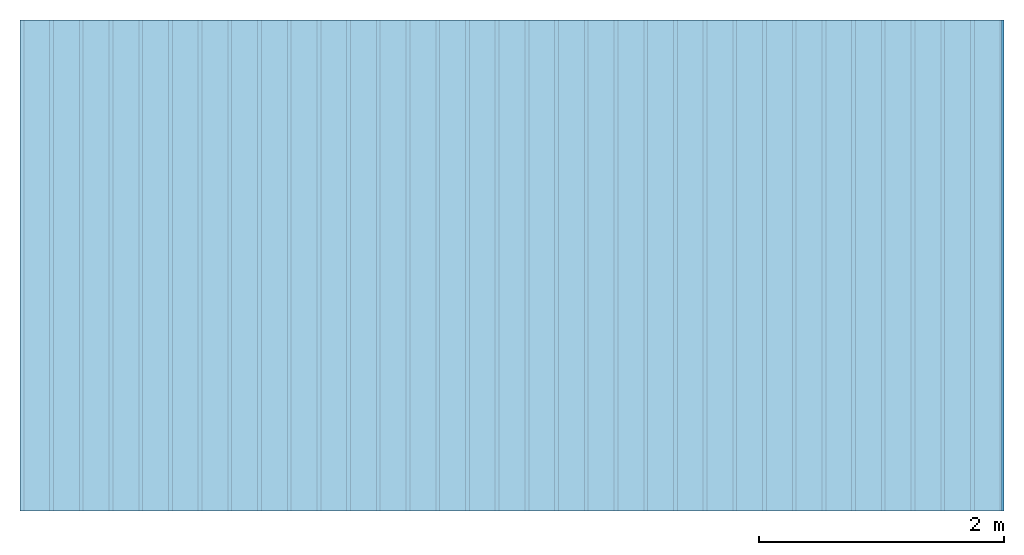
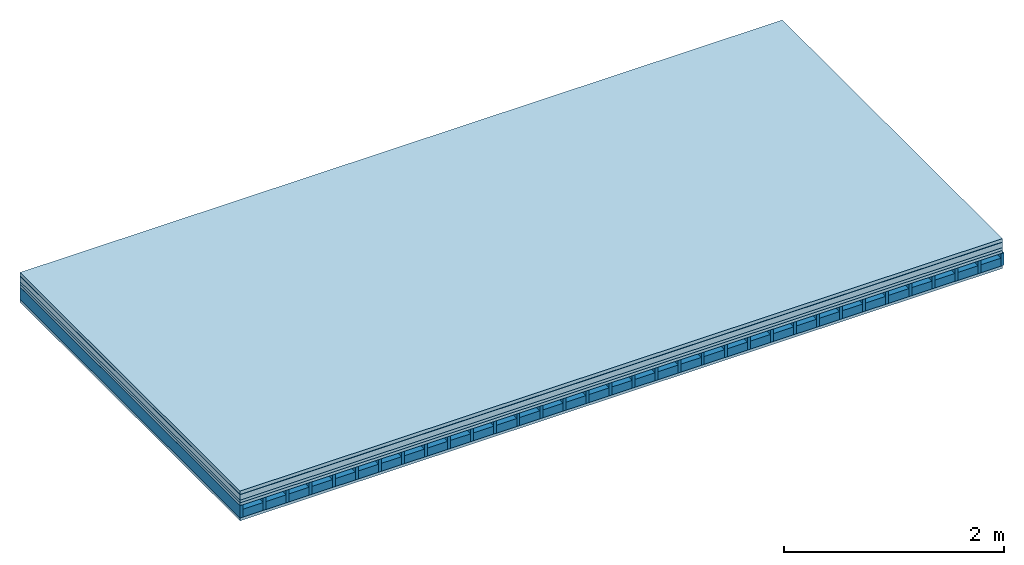
# One storey: 6 plates, 2 members, 1 element without a shape of its own.
"""IFC4 building model written with IfcOpenShell, lengths in metres."""

from ifc_helpers import new_model, si_unit, derived_unit, direction, frame, frame_2d, origin, origin_with_axes, place, context, project, spatial, rectangle, extrude, material, layer, layer_set, type_object, element, aggregate, save


model = new_model("IFC4")

# Units and contexts
plan_context = context("Plan", 3, precision=1e-05, world=origin(), true_north=direction((0.0, 1.0)))
model_context = context("Model", 3, precision=1e-05, world=origin(), true_north=direction((0.0, 1.0)))
ifc_project = project(units=[si_unit("LENGTHUNIT", "METRE"), derived_unit("SOUNDPRESSUREUNIT", [(si_unit("PRESSUREUNIT", "PASCAL", prefix="MICRO"), 0)]), si_unit("ENERGYUNIT", "JOULE", prefix="MEGA"), si_unit("MASSUNIT", "GRAM", prefix="KILO"), derived_unit("THERMALTRANSMITTANCEUNIT", [(si_unit("POWERUNIT", "WATT"), 1), (si_unit("AREAUNIT", "SQUARE_METRE"), -1), (si_unit("THERMODYNAMICTEMPERATUREUNIT", "KELVIN"), -1)]), derived_unit("AREADENSITYUNIT", [(si_unit("MASSUNIT", "GRAM", prefix="KILO"), 1), (si_unit("AREAUNIT", "SQUARE_METRE"), -1)]), derived_unit("USERDEFINED", [(si_unit("ENERGYUNIT", "JOULE", prefix="MEGA"), 1), (si_unit("AREAUNIT", "SQUARE_METRE"), -1)])], contexts=[plan_context, model_context])

# Site, building, storey
site = spatial("IfcSite", under=ifc_project)
building_placement = place(None, origin())
building = spatial("IfcBuilding", under=site, at=building_placement)
storey_placement = place(building_placement, origin())
storey = spatial("IfcBuildingStorey", under=building, at=storey_placement)

# Slab, members, plates
ifc_material_1 = material(Category="03.007")
ifc_layer_1 = layer(ifc_material_1, 0.038, Name="Flooring")
ifc_material_2 = material(Name="TS silent", Category="08.003")
ifc_layer_2 = layer(ifc_material_2, 0.0028, Name="layer")
ifc_material_3 = material(Name="Garden plates", Category="02.007")
ifc_layer_3 = layer(ifc_material_3, 0.06, Name="On-material")
ifc_material_4 = material(Name="EP2, 30mm")
ifc_layer_4 = layer(ifc_material_4, 0.03, Name="Impact sound insulation")
ifc_material_5 = material(Name="surface element sheathing above")
ifc_layer_5 = layer(ifc_material_5, 0.031, Name="Sub-floor")
ifc_layer_6 = layer(None, 0.138, Name="Supporting structure")
ifc_material_6 = material(Name="surface element sheathing below")
ifc_layer_7 = layer(ifc_material_6, 0.031, Name="Lower layer 1")
ifc_layer_set = layer_set([ifc_layer_1, ifc_layer_2, ifc_layer_3, ifc_layer_4, ifc_layer_5, ifc_layer_6, ifc_layer_7])
slab_type = type_object("IfcSlabType", Name="A2702", PredefinedType="NOTDEFINED", material=ifc_layer_set)
slab_placement = place(None, frame((0.0, 0.0, 0.0), z_axis=(0.0, 0.0, -1.0), x_axis=(1.0, 0.0, 0.0)))
slab = element("IfcSlab", 1, at=slab_placement, inside=storey, type_object=slab_type, material=ifc_layer_set, Name="Slab #1")
ifc_material_7 = material(Name="surface element LFE 12")
member_1_placement = place(slab_placement, origin())
member_1 = element("IfcMember", 2, at=member_1_placement, material=ifc_material_7, Name="Supporting structure", context=plan_context, shape_type="SweptSolid", body=[
    extrude(rectangle(XDim=0.031, YDim=0.138, at=frame_2d((0.0155, 0.069), x_axis=(1.0, 0.0))), frame((0.0, 4.0, 0.1618), z_axis=(0.0, -1.0, 0.0), x_axis=(1.0, 0.0, 0.0)), (0.0, 0.0, 1.0), 4.0),
    extrude(rectangle(XDim=0.031, YDim=0.138, at=frame_2d((0.0155, 0.069), x_axis=(1.0, 0.0))), frame((0.242, 4.0, 0.1618), z_axis=(0.0, -1.0, 0.0), x_axis=(1.0, 0.0, 0.0)), (0.0, 0.0, 1.0), 4.0),
    extrude(rectangle(XDim=0.031, YDim=0.138, at=frame_2d((0.0155, 0.069), x_axis=(1.0, 0.0))), frame((0.484, 4.0, 0.1618), z_axis=(0.0, -1.0, 0.0), x_axis=(1.0, 0.0, 0.0)), (0.0, 0.0, 1.0), 4.0),
    extrude(rectangle(XDim=0.031, YDim=0.138, at=frame_2d((0.0155, 0.069), x_axis=(1.0, 0.0))), frame((0.726, 4.0, 0.1618), z_axis=(0.0, -1.0, 0.0), x_axis=(1.0, 0.0, 0.0)), (0.0, 0.0, 1.0), 4.0),
    extrude(rectangle(XDim=0.031, YDim=0.138, at=frame_2d((0.0155, 0.069), x_axis=(1.0, 0.0))), frame((0.968, 4.0, 0.1618), z_axis=(0.0, -1.0, 0.0), x_axis=(1.0, 0.0, 0.0)), (0.0, 0.0, 1.0), 4.0),
    extrude(rectangle(XDim=0.031, YDim=0.138, at=frame_2d((0.0155, 0.069), x_axis=(1.0, 0.0))), frame((1.21, 4.0, 0.1618), z_axis=(0.0, -1.0, 0.0), x_axis=(1.0, 0.0, 0.0)), (0.0, 0.0, 1.0), 4.0),
    extrude(rectangle(XDim=0.031, YDim=0.138, at=frame_2d((0.0155, 0.069), x_axis=(1.0, 0.0))), frame((1.452, 4.0, 0.1618), z_axis=(0.0, -1.0, 0.0), x_axis=(1.0, 0.0, 0.0)), (0.0, 0.0, 1.0), 4.0),
    extrude(rectangle(XDim=0.031, YDim=0.138, at=frame_2d((0.0155, 0.069), x_axis=(1.0, 0.0))), frame((1.694, 4.0, 0.1618), z_axis=(0.0, -1.0, 0.0), x_axis=(1.0, 0.0, 0.0)), (0.0, 0.0, 1.0), 4.0),
    extrude(rectangle(XDim=0.031, YDim=0.138, at=frame_2d((0.0155, 0.069), x_axis=(1.0, 0.0))), frame((1.936, 4.0, 0.1618), z_axis=(0.0, -1.0, 0.0), x_axis=(1.0, 0.0, 0.0)), (0.0, 0.0, 1.0), 4.0),
    extrude(rectangle(XDim=0.031, YDim=0.138, at=frame_2d((0.0155, 0.069), x_axis=(1.0, 0.0))), frame((2.178, 4.0, 0.1618), z_axis=(0.0, -1.0, 0.0), x_axis=(1.0, 0.0, 0.0)), (0.0, 0.0, 1.0), 4.0),
    extrude(rectangle(XDim=0.031, YDim=0.138, at=frame_2d((0.0155, 0.069), x_axis=(1.0, 0.0))), frame((2.42, 4.0, 0.1618), z_axis=(0.0, -1.0, 0.0), x_axis=(1.0, 0.0, 0.0)), (0.0, 0.0, 1.0), 4.0),
    extrude(rectangle(XDim=0.031, YDim=0.138, at=frame_2d((0.0155, 0.069), x_axis=(1.0, 0.0))), frame((2.662, 4.0, 0.1618), z_axis=(0.0, -1.0, 0.0), x_axis=(1.0, 0.0, 0.0)), (0.0, 0.0, 1.0), 4.0),
    extrude(rectangle(XDim=0.031, YDim=0.138, at=frame_2d((0.0155, 0.069), x_axis=(1.0, 0.0))), frame((2.904, 4.0, 0.1618), z_axis=(0.0, -1.0, 0.0), x_axis=(1.0, 0.0, 0.0)), (0.0, 0.0, 1.0), 4.0),
    extrude(rectangle(XDim=0.031, YDim=0.138, at=frame_2d((0.0155, 0.069), x_axis=(1.0, 0.0))), frame((3.146, 4.0, 0.1618), z_axis=(0.0, -1.0, 0.0), x_axis=(1.0, 0.0, 0.0)), (0.0, 0.0, 1.0), 4.0),
    extrude(rectangle(XDim=0.031, YDim=0.138, at=frame_2d((0.0155, 0.069), x_axis=(1.0, 0.0))), frame((3.388, 4.0, 0.1618), z_axis=(0.0, -1.0, 0.0), x_axis=(1.0, 0.0, 0.0)), (0.0, 0.0, 1.0), 4.0),
    extrude(rectangle(XDim=0.031, YDim=0.138, at=frame_2d((0.0155, 0.069), x_axis=(1.0, 0.0))), frame((3.63, 4.0, 0.1618), z_axis=(0.0, -1.0, 0.0), x_axis=(1.0, 0.0, 0.0)), (0.0, 0.0, 1.0), 4.0),
    extrude(rectangle(XDim=0.031, YDim=0.138, at=frame_2d((0.0155, 0.069), x_axis=(1.0, 0.0))), frame((3.872, 4.0, 0.1618), z_axis=(0.0, -1.0, 0.0), x_axis=(1.0, 0.0, 0.0)), (0.0, 0.0, 1.0), 4.0),
    extrude(rectangle(XDim=0.031, YDim=0.138, at=frame_2d((0.0155, 0.069), x_axis=(1.0, 0.0))), frame((4.114, 4.0, 0.1618), z_axis=(0.0, -1.0, 0.0), x_axis=(1.0, 0.0, 0.0)), (0.0, 0.0, 1.0), 4.0),
    extrude(rectangle(XDim=0.031, YDim=0.138, at=frame_2d((0.0155, 0.069), x_axis=(1.0, 0.0))), frame((4.356, 4.0, 0.1618), z_axis=(0.0, -1.0, 0.0), x_axis=(1.0, 0.0, 0.0)), (0.0, 0.0, 1.0), 4.0),
    extrude(rectangle(XDim=0.031, YDim=0.138, at=frame_2d((0.0155, 0.069), x_axis=(1.0, 0.0))), frame((4.598, 4.0, 0.1618), z_axis=(0.0, -1.0, 0.0), x_axis=(1.0, 0.0, 0.0)), (0.0, 0.0, 1.0), 4.0),
    extrude(rectangle(XDim=0.031, YDim=0.138, at=frame_2d((0.0155, 0.069), x_axis=(1.0, 0.0))), frame((4.84, 4.0, 0.1618), z_axis=(0.0, -1.0, 0.0), x_axis=(1.0, 0.0, 0.0)), (0.0, 0.0, 1.0), 4.0),
    extrude(rectangle(XDim=0.031, YDim=0.138, at=frame_2d((0.0155, 0.069), x_axis=(1.0, 0.0))), frame((5.082, 4.0, 0.1618), z_axis=(0.0, -1.0, 0.0), x_axis=(1.0, 0.0, 0.0)), (0.0, 0.0, 1.0), 4.0),
    extrude(rectangle(XDim=0.031, YDim=0.138, at=frame_2d((0.0155, 0.069), x_axis=(1.0, 0.0))), frame((5.324, 4.0, 0.1618), z_axis=(0.0, -1.0, 0.0), x_axis=(1.0, 0.0, 0.0)), (0.0, 0.0, 1.0), 4.0),
    extrude(rectangle(XDim=0.031, YDim=0.138, at=frame_2d((0.0155, 0.069), x_axis=(1.0, 0.0))), frame((5.566, 4.0, 0.1618), z_axis=(0.0, -1.0, 0.0), x_axis=(1.0, 0.0, 0.0)), (0.0, 0.0, 1.0), 4.0),
    extrude(rectangle(XDim=0.031, YDim=0.138, at=frame_2d((0.0155, 0.069), x_axis=(1.0, 0.0))), frame((5.808, 4.0, 0.1618), z_axis=(0.0, -1.0, 0.0), x_axis=(1.0, 0.0, 0.0)), (0.0, 0.0, 1.0), 4.0),
    extrude(rectangle(XDim=0.031, YDim=0.138, at=frame_2d((0.0155, 0.069), x_axis=(1.0, 0.0))), frame((6.05, 4.0, 0.1618), z_axis=(0.0, -1.0, 0.0), x_axis=(1.0, 0.0, 0.0)), (0.0, 0.0, 1.0), 4.0),
    extrude(rectangle(XDim=0.031, YDim=0.138, at=frame_2d((0.0155, 0.069), x_axis=(1.0, 0.0))), frame((6.292, 4.0, 0.1618), z_axis=(0.0, -1.0, 0.0), x_axis=(1.0, 0.0, 0.0)), (0.0, 0.0, 1.0), 4.0),
    extrude(rectangle(XDim=0.031, YDim=0.138, at=frame_2d((0.0155, 0.069), x_axis=(1.0, 0.0))), frame((6.534, 4.0, 0.1618), z_axis=(0.0, -1.0, 0.0), x_axis=(1.0, 0.0, 0.0)), (0.0, 0.0, 1.0), 4.0),
    extrude(rectangle(XDim=0.031, YDim=0.138, at=frame_2d((0.0155, 0.069), x_axis=(1.0, 0.0))), frame((6.776, 4.0, 0.1618), z_axis=(0.0, -1.0, 0.0), x_axis=(1.0, 0.0, 0.0)), (0.0, 0.0, 1.0), 4.0),
    extrude(rectangle(XDim=0.031, YDim=0.138, at=frame_2d((0.0155, 0.069), x_axis=(1.0, 0.0))), frame((7.018, 4.0, 0.1618), z_axis=(0.0, -1.0, 0.0), x_axis=(1.0, 0.0, 0.0)), (0.0, 0.0, 1.0), 4.0),
    extrude(rectangle(XDim=0.031, YDim=0.138, at=frame_2d((0.0155, 0.069), x_axis=(1.0, 0.0))), frame((7.26, 4.0, 0.1618), z_axis=(0.0, -1.0, 0.0), x_axis=(1.0, 0.0, 0.0)), (0.0, 0.0, 1.0), 4.0),
    extrude(rectangle(XDim=0.031, YDim=0.138, at=frame_2d((0.0155, 0.069), x_axis=(1.0, 0.0))), frame((7.502, 4.0, 0.1618), z_axis=(0.0, -1.0, 0.0), x_axis=(1.0, 0.0, 0.0)), (0.0, 0.0, 1.0), 4.0),
    extrude(rectangle(XDim=0.031, YDim=0.138, at=frame_2d((0.0155, 0.069), x_axis=(1.0, 0.0))), frame((7.744, 4.0, 0.1618), z_axis=(0.0, -1.0, 0.0), x_axis=(1.0, 0.0, 0.0)), (0.0, 0.0, 1.0), 4.0),
    extrude(rectangle(XDim=0.031, YDim=0.138, at=frame_2d((0.0155, 0.069), x_axis=(1.0, 0.0))), frame((7.986, 4.0, 0.1618), z_axis=(0.0, -1.0, 0.0), x_axis=(1.0, 0.0, 0.0)), (0.0, 0.0, 1.0), 4.0),
])
ifc_material_8 = material(Name="Damper and limestone LFE 12")
member_2_placement = place(slab_placement, origin())
member_2 = element("IfcMember", 3, at=member_2_placement, material=ifc_material_8, Name="in supporting structure", context=plan_context, shape_type="SweptSolid", body=[
    extrude(rectangle(XDim=0.211, YDim=0.088, at=frame_2d((0.1055, 0.044), x_axis=(1.0, 0.0))), frame((0.031, 4.0, 0.2118), z_axis=(0.0, -1.0, 0.0), x_axis=(1.0, 0.0, 0.0)), (0.0, 0.0, 1.0), 4.0),
    extrude(rectangle(XDim=0.211, YDim=0.088, at=frame_2d((0.1055, 0.044), x_axis=(1.0, 0.0))), frame((0.273, 4.0, 0.2118), z_axis=(0.0, -1.0, 0.0), x_axis=(1.0, 0.0, 0.0)), (0.0, 0.0, 1.0), 4.0),
    extrude(rectangle(XDim=0.211, YDim=0.088, at=frame_2d((0.1055, 0.044), x_axis=(1.0, 0.0))), frame((0.515, 4.0, 0.2118), z_axis=(0.0, -1.0, 0.0), x_axis=(1.0, 0.0, 0.0)), (0.0, 0.0, 1.0), 4.0),
    extrude(rectangle(XDim=0.211, YDim=0.088, at=frame_2d((0.1055, 0.044), x_axis=(1.0, 0.0))), frame((0.757, 4.0, 0.2118), z_axis=(0.0, -1.0, 0.0), x_axis=(1.0, 0.0, 0.0)), (0.0, 0.0, 1.0), 4.0),
    extrude(rectangle(XDim=0.211, YDim=0.088, at=frame_2d((0.1055, 0.044), x_axis=(1.0, 0.0))), frame((0.999, 4.0, 0.2118), z_axis=(0.0, -1.0, 0.0), x_axis=(1.0, 0.0, 0.0)), (0.0, 0.0, 1.0), 4.0),
    extrude(rectangle(XDim=0.211, YDim=0.088, at=frame_2d((0.1055, 0.044), x_axis=(1.0, 0.0))), frame((1.241, 4.0, 0.2118), z_axis=(0.0, -1.0, 0.0), x_axis=(1.0, 0.0, 0.0)), (0.0, 0.0, 1.0), 4.0),
    extrude(rectangle(XDim=0.211, YDim=0.088, at=frame_2d((0.1055, 0.044), x_axis=(1.0, 0.0))), frame((1.483, 4.0, 0.2118), z_axis=(0.0, -1.0, 0.0), x_axis=(1.0, 0.0, 0.0)), (0.0, 0.0, 1.0), 4.0),
    extrude(rectangle(XDim=0.211, YDim=0.088, at=frame_2d((0.1055, 0.044), x_axis=(1.0, 0.0))), frame((1.725, 4.0, 0.2118), z_axis=(0.0, -1.0, 0.0), x_axis=(1.0, 0.0, 0.0)), (0.0, 0.0, 1.0), 4.0),
    extrude(rectangle(XDim=0.211, YDim=0.088, at=frame_2d((0.1055, 0.044), x_axis=(1.0, 0.0))), frame((1.967, 4.0, 0.2118), z_axis=(0.0, -1.0, 0.0), x_axis=(1.0, 0.0, 0.0)), (0.0, 0.0, 1.0), 4.0),
    extrude(rectangle(XDim=0.211, YDim=0.088, at=frame_2d((0.1055, 0.044), x_axis=(1.0, 0.0))), frame((2.209, 4.0, 0.2118), z_axis=(0.0, -1.0, 0.0), x_axis=(1.0, 0.0, 0.0)), (0.0, 0.0, 1.0), 4.0),
    extrude(rectangle(XDim=0.211, YDim=0.088, at=frame_2d((0.1055, 0.044), x_axis=(1.0, 0.0))), frame((2.451, 4.0, 0.2118), z_axis=(0.0, -1.0, 0.0), x_axis=(1.0, 0.0, 0.0)), (0.0, 0.0, 1.0), 4.0),
    extrude(rectangle(XDim=0.211, YDim=0.088, at=frame_2d((0.1055, 0.044), x_axis=(1.0, 0.0))), frame((2.693, 4.0, 0.2118), z_axis=(0.0, -1.0, 0.0), x_axis=(1.0, 0.0, 0.0)), (0.0, 0.0, 1.0), 4.0),
    extrude(rectangle(XDim=0.211, YDim=0.088, at=frame_2d((0.1055, 0.044), x_axis=(1.0, 0.0))), frame((2.935, 4.0, 0.2118), z_axis=(0.0, -1.0, 0.0), x_axis=(1.0, 0.0, 0.0)), (0.0, 0.0, 1.0), 4.0),
    extrude(rectangle(XDim=0.211, YDim=0.088, at=frame_2d((0.1055, 0.044), x_axis=(1.0, 0.0))), frame((3.177, 4.0, 0.2118), z_axis=(0.0, -1.0, 0.0), x_axis=(1.0, 0.0, 0.0)), (0.0, 0.0, 1.0), 4.0),
    extrude(rectangle(XDim=0.211, YDim=0.088, at=frame_2d((0.1055, 0.044), x_axis=(1.0, 0.0))), frame((3.419, 4.0, 0.2118), z_axis=(0.0, -1.0, 0.0), x_axis=(1.0, 0.0, 0.0)), (0.0, 0.0, 1.0), 4.0),
    extrude(rectangle(XDim=0.211, YDim=0.088, at=frame_2d((0.1055, 0.044), x_axis=(1.0, 0.0))), frame((3.661, 4.0, 0.2118), z_axis=(0.0, -1.0, 0.0), x_axis=(1.0, 0.0, 0.0)), (0.0, 0.0, 1.0), 4.0),
    extrude(rectangle(XDim=0.211, YDim=0.088, at=frame_2d((0.1055, 0.044), x_axis=(1.0, 0.0))), frame((3.903, 4.0, 0.2118), z_axis=(0.0, -1.0, 0.0), x_axis=(1.0, 0.0, 0.0)), (0.0, 0.0, 1.0), 4.0),
    extrude(rectangle(XDim=0.211, YDim=0.088, at=frame_2d((0.1055, 0.044), x_axis=(1.0, 0.0))), frame((4.145, 4.0, 0.2118), z_axis=(0.0, -1.0, 0.0), x_axis=(1.0, 0.0, 0.0)), (0.0, 0.0, 1.0), 4.0),
    extrude(rectangle(XDim=0.211, YDim=0.088, at=frame_2d((0.1055, 0.044), x_axis=(1.0, 0.0))), frame((4.387, 4.0, 0.2118), z_axis=(0.0, -1.0, 0.0), x_axis=(1.0, 0.0, 0.0)), (0.0, 0.0, 1.0), 4.0),
    extrude(rectangle(XDim=0.211, YDim=0.088, at=frame_2d((0.1055, 0.044), x_axis=(1.0, 0.0))), frame((4.629, 4.0, 0.2118), z_axis=(0.0, -1.0, 0.0), x_axis=(1.0, 0.0, 0.0)), (0.0, 0.0, 1.0), 4.0),
    extrude(rectangle(XDim=0.211, YDim=0.088, at=frame_2d((0.1055, 0.044), x_axis=(1.0, 0.0))), frame((4.871, 4.0, 0.2118), z_axis=(0.0, -1.0, 0.0), x_axis=(1.0, 0.0, 0.0)), (0.0, 0.0, 1.0), 4.0),
    extrude(rectangle(XDim=0.211, YDim=0.088, at=frame_2d((0.1055, 0.044), x_axis=(1.0, 0.0))), frame((5.113, 4.0, 0.2118), z_axis=(0.0, -1.0, 0.0), x_axis=(1.0, 0.0, 0.0)), (0.0, 0.0, 1.0), 4.0),
    extrude(rectangle(XDim=0.211, YDim=0.088, at=frame_2d((0.1055, 0.044), x_axis=(1.0, 0.0))), frame((5.355, 4.0, 0.2118), z_axis=(0.0, -1.0, 0.0), x_axis=(1.0, 0.0, 0.0)), (0.0, 0.0, 1.0), 4.0),
    extrude(rectangle(XDim=0.211, YDim=0.088, at=frame_2d((0.1055, 0.044), x_axis=(1.0, 0.0))), frame((5.597, 4.0, 0.2118), z_axis=(0.0, -1.0, 0.0), x_axis=(1.0, 0.0, 0.0)), (0.0, 0.0, 1.0), 4.0),
    extrude(rectangle(XDim=0.211, YDim=0.088, at=frame_2d((0.1055, 0.044), x_axis=(1.0, 0.0))), frame((5.839, 4.0, 0.2118), z_axis=(0.0, -1.0, 0.0), x_axis=(1.0, 0.0, 0.0)), (0.0, 0.0, 1.0), 4.0),
    extrude(rectangle(XDim=0.211, YDim=0.088, at=frame_2d((0.1055, 0.044), x_axis=(1.0, 0.0))), frame((6.081, 4.0, 0.2118), z_axis=(0.0, -1.0, 0.0), x_axis=(1.0, 0.0, 0.0)), (0.0, 0.0, 1.0), 4.0),
    extrude(rectangle(XDim=0.211, YDim=0.088, at=frame_2d((0.1055, 0.044), x_axis=(1.0, 0.0))), frame((6.323, 4.0, 0.2118), z_axis=(0.0, -1.0, 0.0), x_axis=(1.0, 0.0, 0.0)), (0.0, 0.0, 1.0), 4.0),
    extrude(rectangle(XDim=0.211, YDim=0.088, at=frame_2d((0.1055, 0.044), x_axis=(1.0, 0.0))), frame((6.565, 4.0, 0.2118), z_axis=(0.0, -1.0, 0.0), x_axis=(1.0, 0.0, 0.0)), (0.0, 0.0, 1.0), 4.0),
    extrude(rectangle(XDim=0.211, YDim=0.088, at=frame_2d((0.1055, 0.044), x_axis=(1.0, 0.0))), frame((6.807, 4.0, 0.2118), z_axis=(0.0, -1.0, 0.0), x_axis=(1.0, 0.0, 0.0)), (0.0, 0.0, 1.0), 4.0),
    extrude(rectangle(XDim=0.211, YDim=0.088, at=frame_2d((0.1055, 0.044), x_axis=(1.0, 0.0))), frame((7.049, 4.0, 0.2118), z_axis=(0.0, -1.0, 0.0), x_axis=(1.0, 0.0, 0.0)), (0.0, 0.0, 1.0), 4.0),
    extrude(rectangle(XDim=0.211, YDim=0.088, at=frame_2d((0.1055, 0.044), x_axis=(1.0, 0.0))), frame((7.291, 4.0, 0.2118), z_axis=(0.0, -1.0, 0.0), x_axis=(1.0, 0.0, 0.0)), (0.0, 0.0, 1.0), 4.0),
    extrude(rectangle(XDim=0.211, YDim=0.088, at=frame_2d((0.1055, 0.044), x_axis=(1.0, 0.0))), frame((7.533, 4.0, 0.2118), z_axis=(0.0, -1.0, 0.0), x_axis=(1.0, 0.0, 0.0)), (0.0, 0.0, 1.0), 4.0),
    extrude(rectangle(XDim=0.211, YDim=0.088, at=frame_2d((0.1055, 0.044), x_axis=(1.0, 0.0))), frame((7.775, 4.0, 0.2118), z_axis=(0.0, -1.0, 0.0), x_axis=(1.0, 0.0, 0.0)), (0.0, 0.0, 1.0), 4.0),
])
plate_1_placement = place(slab_placement, origin())
plate_1 = element("IfcPlate", 4, at=plate_1_placement, material=ifc_material_1, Name="Flooring", context=plan_context, shape_type="SweptSolid", body=[
    extrude(rectangle(XDim=8.0, YDim=4.0, at=frame_2d((4.0, 2.0), x_axis=(1.0, 0.0))), origin_with_axes(), (0.0, 0.0, 1.0), 0.038),
])
plate_2_placement = place(slab_placement, origin())
plate_2 = element("IfcPlate", 5, at=plate_2_placement, material=ifc_material_2, Name="layer", context=plan_context, shape_type="SweptSolid", body=[
    extrude(rectangle(XDim=8.0, YDim=4.0, at=frame_2d((4.0, 2.0), x_axis=(1.0, 0.0))), frame((0.0, 0.0, 0.038), z_axis=(0.0, 0.0, 1.0), x_axis=(1.0, 0.0, 0.0)), (0.0, 0.0, 1.0), 0.0028),
])
plate_3_placement = place(slab_placement, origin())
plate_3 = element("IfcPlate", 6, at=plate_3_placement, material=ifc_material_3, Name="On-material", context=plan_context, shape_type="SweptSolid", body=[
    extrude(rectangle(XDim=8.0, YDim=4.0, at=frame_2d((4.0, 2.0), x_axis=(1.0, 0.0))), frame((0.0, 0.0, 0.0408), z_axis=(0.0, 0.0, 1.0), x_axis=(1.0, 0.0, 0.0)), (0.0, 0.0, 1.0), 0.06),
])
plate_4_placement = place(slab_placement, origin())
plate_4 = element("IfcPlate", 7, at=plate_4_placement, material=ifc_material_4, Name="Impact sound insulation", context=plan_context, shape_type="SweptSolid", body=[
    extrude(rectangle(XDim=8.0, YDim=4.0, at=frame_2d((4.0, 2.0), x_axis=(1.0, 0.0))), frame((0.0, 0.0, 0.1008), z_axis=(0.0, 0.0, 1.0), x_axis=(1.0, 0.0, 0.0)), (0.0, 0.0, 1.0), 0.03),
])
plate_5_placement = place(slab_placement, origin())
plate_5 = element("IfcPlate", 8, at=plate_5_placement, material=ifc_material_5, Name="Sub-floor", context=plan_context, shape_type="SweptSolid", body=[
    extrude(rectangle(XDim=8.0, YDim=4.0, at=frame_2d((4.0, 2.0), x_axis=(1.0, 0.0))), frame((0.0, 0.0, 0.1308), z_axis=(0.0, 0.0, 1.0), x_axis=(1.0, 0.0, 0.0)), (0.0, 0.0, 1.0), 0.031),
])
plate_6_placement = place(slab_placement, origin())
plate_6 = element("IfcPlate", 9, at=plate_6_placement, material=ifc_material_6, Name="Lower layer 1", context=plan_context, shape_type="SweptSolid", body=[
    extrude(rectangle(XDim=8.0, YDim=4.0, at=frame_2d((4.0, 2.0), x_axis=(1.0, 0.0))), frame((0.0, 0.0, 0.2998), z_axis=(0.0, 0.0, 1.0), x_axis=(1.0, 0.0, 0.0)), (0.0, 0.0, 1.0), 0.031),
])
aggregate(slab, [plate_1, plate_2, plate_3, plate_4, plate_5, member_1, member_2, plate_6])

save(model, "model.ifc")
